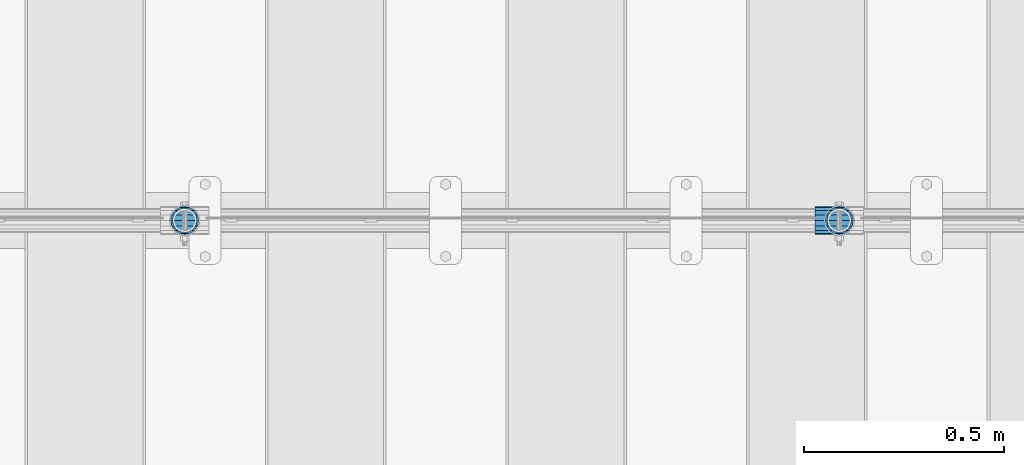
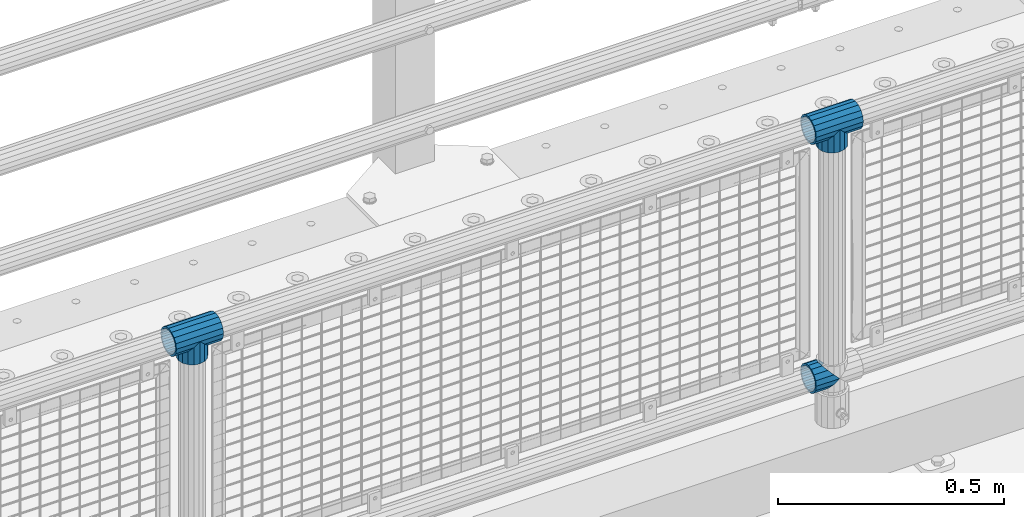
# One storey, part 180 of 270: 5 beams.
"""IFC2X3 building model written with IfcOpenShell, lengths in millimetres."""

from ifc_helpers import new_model, si_unit, frame, origin_with_axes, place, context, subcontext, project, spatial, faceted_brep, material, type_object, element, save


model = new_model("IFC2X3")

# Units and contexts
model_context = context("Model", 3, precision=1e-05, world=origin_with_axes())
body_context = subcontext(model_context, "Body", "Model", "MODEL_VIEW")
ifc_project = project(units=[si_unit("LENGTHUNIT", "METRE", prefix="MILLI"), si_unit("AREAUNIT", "SQUARE_METRE"), si_unit("VOLUMEUNIT", "CUBIC_METRE"), si_unit("MASSUNIT", "GRAM", prefix="KILO"), si_unit("TIMEUNIT", "SECOND"), si_unit("PLANEANGLEUNIT", "RADIAN"), si_unit("SOLIDANGLEUNIT", "STERADIAN"), si_unit("THERMODYNAMICTEMPERATUREUNIT", "DEGREE_CELSIUS"), si_unit("LUMINOUSINTENSITYUNIT", "LUMEN")], contexts=[model_context])

# Site, building, storey
site_placement = place(None, origin_with_axes())
site = spatial("IfcSite", under=ifc_project, at=site_placement, CompositionType="ELEMENT")
building_placement = place(site_placement, origin_with_axes())
building = spatial("IfcBuilding", under=site, at=building_placement, Name="Standard", CompositionType="ELEMENT")
storey_placement = place(building_placement, origin_with_axes())
storey = spatial("IfcBuildingStorey", under=building, at=storey_placement, Name="Undefined", CompositionType="ELEMENT", Elevation=0.0)

# Beams
ifc_material = material(Name="Misc_Undefined")
beam_type = type_object("IfcBeamType", PredefinedType="NOTDEFINED")
beam_1_placement = place(storey_placement, frame((16890.85, -16335.5, 298.17), z_axis=(0.0, 1.0, 0.0), x_axis=(1.0, 0.0, 0.0)))
element("IfcBeam", 1, at=beam_1_placement, inside=storey, type_object=beam_type, material=ifc_material, context=body_context, shape_type="Brep", body=[
    faceted_brep([(60.1499999999978, 0.0, -35.1499999999996), (46.698677352364, 13.4513226476329, -32.4743655677721), (46.698677352364, -13.4513226476329, -32.4743655677721), (33.0273231408937, 21.4606908090117, 21.4606908090118), (27.6756344322275, 26.8123795176776, 13.4513226476338), (27.6756344322275, 32.4743655677717, 13.4513226476338), (35.2951966412911, 24.8548033587072, 24.8548033587067), (35.2951966412911, 16.3810424080045, 24.8548033587067), (27.310256188277, 28.0397438117175, 11.6144421722802), (24.9999999999964, 30.35, 0.0), (24.9999999999964, 35.15, 0.0), (27.6756344322275, 26.8123795176775, -13.4513226476338), (27.6756344322275, 32.4743655677717, -13.4513226476338), (27.310256188277, 28.0397438117175, -11.6144421722802), (35.2951966412911, 16.3810424080045, -24.8548033587067), (35.2951966412911, 24.8548033587072, -24.8548033587067), (33.0273231408937, 21.4606908090117, -21.4606908090118), (40.0617968770166, 11.6144421722805, -28.0397438117179), (43.519339601633, 0.0, -30.3500000000004), (40.0617968770166, -11.6144421722805, -28.0397438117179), (35.2951966412911, -16.3810424080045, -24.8548033587067), (35.2951966412911, -24.8548033587072, -24.8548033587067), (33.0273231408937, -21.4606908090117, -21.4606908090118), (27.6756344322275, -26.8123795176776, -13.4513226476338), (27.6756344322275, -32.4743655677717, -13.4513226476338), (27.310256188277, -28.0397438117175, -11.6144421722802), (24.9999999999964, -30.35, 0.0), (24.9999999999964, -35.15, 0.0), (27.310256188277, -28.0397438117175, 11.6144421722802), (27.6756344322275, -26.8123795176775, 13.4513226476338), (27.6756344322275, -32.4743655677717, 13.4513226476338), (33.0273231408937, -21.4606908090117, 21.4606908090118), (35.2951966412911, -16.3810424080078, 24.8548033587067), (35.2951966412911, -24.8548033587072, 24.8548033587067), (60.1499999999978, 0.0, 35.1499999999996), (46.698677352364, -13.4513226476329, 32.4743655677721), (46.698677352364, 13.4513226476329, 32.4743655677721), (40.061796877013, -11.6144421722805, 28.0397438117179), (43.5193396016293, 0.0, 30.3500000000004), (40.061796877013, 11.6144421722805, 28.0397438117179), (0.0, -32.4743655677721, -13.4513226476338), (0.0, -24.8548033587067, -24.8548033587067), (0.0, -13.4513226476338, -32.4743655677703), (0.0, 0.0, -35.1499999999996), (0.0, 13.4513226476338, -32.4743655677703), (0.0, 24.8548033587067, -24.8548033587067), (0.0, 32.4743655677721, -13.4513226476338), (0.0, 35.1499999999996, 0.0), (0.0, 32.4743655677721, 13.4513226476338), (0.0, 24.8548033587067, 24.8548033587067), (0.0, 13.4513226476338, 32.4743655677703), (0.0, 0.0, 35.1499999999996), (0.0, -32.4743655677721, 13.4513226476338), (0.0, -35.1499999999996, 0.0), (0.0, -24.8548033587067, 24.8548033587067), (0.0, -13.4513226476338, 32.4743655677703), (0.0, -28.0397438117179, -11.614442172282), (0.0, -21.4606908090118, -21.46069080901), (0.0, -11.6144421722802, -28.0397438117179), (0.0, 0.0, -30.3499999999985), (0.0, 11.6144421722802, -28.0397438117179), (0.0, 21.4606908090118, -21.46069080901), (0.0, 28.0397438117179, -11.614442172282), (0.0, 30.3500000000004, 0.0), (0.0, 28.0397438117179, 11.614442172282), (0.0, 21.4606908090118, 21.46069080901), (0.0, 11.6144421722802, 28.0397438117179), (0.0, 0.0, 30.3499999999985), (0.0, -11.6144421722802, 28.0397438117179), (0.0, -21.4606908090118, 21.46069080901), (0.0, -28.0397438117179, 11.614442172282), (0.0, -30.3500000000004, 0.0)], [[[0, 1, 2]], [[3, 4, 5, 6, 7]], [[8, 9, 10, 5, 4]], [[11, 12, 10, 9, 13]], [[14, 15, 12, 11, 16]], [[2, 1, 15, 14, 17, 18, 19, 20, 21]], [[21, 20, 22, 23, 24]], [[24, 23, 25, 26, 27]], [[27, 26, 28, 29, 30]], [[30, 29, 31, 32, 33]], [[34, 35, 36]], [[33, 32, 37, 38, 39, 7, 6, 36, 35]], [[40, 41, 21, 24]], [[41, 42, 2, 21]], [[42, 43, 0, 2]], [[43, 44, 1, 0]], [[44, 45, 15, 1]], [[45, 46, 12, 15]], [[46, 47, 10, 12]], [[47, 48, 5, 10]], [[48, 49, 6, 5]], [[49, 50, 36, 6]], [[50, 51, 34, 36]], [[52, 53, 27, 30]], [[54, 52, 30, 33]], [[55, 54, 33, 35]], [[51, 55, 35, 34]], [[53, 40, 24, 27]], [[52, 54, 55, 51, 50, 49, 48, 47, 46, 45, 44, 43, 42, 41, 40, 53], [56, 57, 58, 59, 60, 61, 62, 63, 64, 65, 66, 67, 68, 69, 70, 71]], [[68, 67, 38, 37]], [[31, 69, 68, 37, 32]], [[28, 70, 69, 31, 29]], [[71, 70, 28, 26]], [[56, 71, 26, 25]], [[57, 56, 25, 23, 22]], [[58, 57, 22, 20, 19]], [[59, 58, 19, 18]], [[60, 59, 18, 17]], [[16, 61, 60, 17, 14]], [[13, 62, 61, 16, 11]], [[63, 62, 13, 9]], [[64, 63, 9, 8]], [[65, 64, 8, 4, 3]], [[66, 65, 3, 7, 39]], [[67, 66, 39, 38]]]),
])
beam_2_placement = place(storey_placement, frame((15318.0, -16335.5, 969.849999999999), z_axis=(0.0, 1.0, 0.0), x_axis=(0.0, 0.0, -1.0)))
element("IfcBeam", 2, at=beam_2_placement, inside=storey, type_object=beam_type, material=ifc_material, context=body_context, shape_type="Brep", body=[
    faceted_brep([(13.4513226476338, 13.4513226476329, 32.4743655677721), (13.4513226476338, -13.4513226476329, 32.4743655677721), (0.0, 0.0, 35.1499999999996), (27.1226768591041, -21.4606908090117, -21.4606908090118), (24.8548033587067, -16.3810424080045, -24.8548033587067), (24.8548033587067, -24.8548033587072, -24.8548033587067), (32.4743655677703, -32.4743655677717, -13.4513226476338), (32.4743655677703, -26.8123795176776, -13.4513226476338), (0.0, 0.0, -35.1499999999996), (13.4513226476338, -13.4513226476329, -32.4743655677721), (13.4513226476338, 13.4513226476329, -32.4743655677721), (20.0882031229849, -11.6144421722805, -28.0397438117179), (16.6306603983721, 0.0, -30.3500000000004), (20.0882031229849, 11.6144421722805, -28.0397438117179), (24.8548033587067, 16.3810424080045, -24.8548033587067), (24.8548033587067, 24.8548033587072, -24.8548033587067), (27.1226768591041, 21.4606908090117, -21.4606908090118), (32.4743655677703, 26.8123795176775, -13.4513226476338), (32.4743655677703, 32.4743655677717, -13.4513226476338), (32.8397438117172, 28.0397438117175, -11.6144421722802), (35.1500000000015, 30.35, 0.0), (35.1500000000015, 35.1500000000003, 0.0), (32.8397438117208, 28.0397438117175, 11.6144421722802), (32.4743655677703, 26.8123795176776, 13.4513226476338), (32.4743655677703, 32.4743655677717, 13.4513226476338), (27.1226768591041, 21.4606908090117, 21.4606908090118), (24.8548033587067, 16.3810424080045, 24.8548033587067), (24.8548033587067, 24.8548033587072, 24.8548033587067), (20.0882031229812, 11.6144421722805, 28.0397438117179), (16.6306603983612, 0.0, 30.3500000000004), (20.0882031229812, -11.6144421722805, 28.0397438117179), (24.8548033587067, -16.3810424080045, 24.8548033587067), (24.8548033587067, -24.8548033587072, 24.8548033587067), (32.4743655677703, -26.8123795176775, 13.4513226476338), (32.4743655677703, -32.4743655677717, 13.4513226476338), (27.1226768591041, -21.4606908090117, 21.4606908090118), (35.1500000000015, -30.35, 0.0), (35.1500000000015, -35.15, 0.0), (32.8397438117208, -28.0397438117175, 11.6144421722802), (32.8397438117172, -28.0397438117175, -11.6144421722802), (60.1500000000015, -24.8548033587072, -24.8548033587067), (60.1500000000015, -32.4743655677717, -13.4513226476338), (60.1500000000015, -13.4513226476329, -32.4743655677721), (60.1499999999978, 0.0, -35.1499999999996), (60.1500000000015, 13.4513226476329, -32.4743655677721), (60.1500000000015, 24.8548033587072, -24.8548033587067), (60.1500000000015, 32.4743655677717, -13.4513226476338), (60.1500000000015, 35.15, 0.0), (60.1500000000015, 32.4743655677717, 13.4513226476338), (60.1500000000015, 24.8548033587072, 24.8548033587067), (60.1500000000015, 13.4513226476329, 32.4743655677721), (60.1499999999978, 0.0, 35.1499999999996), (60.1500000000015, -13.4513226476329, 32.4743655677721), (60.1500000000015, -24.8548033587072, 24.8548033587067), (60.1500000000015, -32.4743655677717, 13.4513226476338), (60.1500000000015, -35.15, 0.0), (60.1500000000015, -21.4606908090117, 21.4606908090118), (60.1500000000015, -11.6144421722805, 28.0397438117179), (60.1500000000015, 0.0, 30.3500000000004), (60.1500000000015, 11.6144421722805, 28.0397438117179), (60.1500000000015, 21.4606908090117, 21.4606908090118), (60.1500000000015, 28.0397438117175, 11.6144421722802), (60.1500000000015, 30.35, 0.0), (60.1500000000015, 28.0397438117175, -11.6144421722802), (60.1500000000015, 21.4606908090117, -21.4606908090118), (60.1500000000015, 11.6144421722805, -28.0397438117179), (60.1500000000015, 0.0, -30.3500000000004), (60.1500000000015, -11.6144421722805, -28.0397438117179), (60.1500000000015, -21.4606908090117, -21.4606908090118), (60.1500000000015, -28.0397438117175, -11.6144421722802), (60.1500000000015, -30.35, 0.0), (60.1500000000015, -28.0397438117175, 11.6144421722802)], [[[0, 1, 2]], [[3, 4, 5, 6, 7]], [[8, 9, 10]], [[10, 9, 5, 4, 11, 12, 13, 14, 15]], [[15, 14, 16, 17, 18]], [[18, 17, 19, 20, 21]], [[21, 20, 22, 23, 24]], [[24, 23, 25, 26, 27]], [[27, 26, 28, 29, 30, 31, 32, 1, 0]], [[33, 34, 32, 31, 35]], [[36, 37, 34, 33, 38]], [[39, 7, 6, 37, 36]], [[40, 41, 6, 5]], [[42, 40, 5, 9]], [[43, 42, 9, 8]], [[44, 43, 8, 10]], [[45, 44, 10, 15]], [[46, 45, 15, 18]], [[47, 46, 18, 21]], [[48, 47, 21, 24]], [[49, 48, 24, 27]], [[50, 49, 27, 0]], [[51, 50, 0, 2]], [[52, 51, 2, 1]], [[53, 52, 1, 32]], [[54, 53, 32, 34]], [[55, 54, 34, 37]], [[41, 55, 37, 6]], [[40, 42, 43, 44, 45, 46, 47, 48, 49, 50, 51, 52, 53, 54, 55, 41], [56, 57, 58, 59, 60, 61, 62, 63, 64, 65, 66, 67, 68, 69, 70, 71]], [[71, 70, 36, 38]], [[35, 56, 71, 38, 33]], [[30, 57, 56, 35, 31]], [[58, 57, 30, 29]], [[59, 58, 29, 28]], [[60, 59, 28, 26, 25]], [[61, 60, 25, 23, 22]], [[62, 61, 22, 20]], [[63, 62, 20, 19]], [[16, 64, 63, 19, 17]], [[13, 65, 64, 16, 14]], [[66, 65, 13, 12]], [[67, 66, 12, 11]], [[68, 67, 11, 4, 3]], [[69, 68, 3, 7, 39]], [[70, 69, 39, 36]]]),
])
beam_3_placement = place(storey_placement, frame((15257.85, -16335.5, 969.849999999999), z_axis=(0.0, 0.0, 1.0), x_axis=(1.0, 0.0, 0.0)))
element("IfcBeam", 3, at=beam_3_placement, inside=storey, type_object=beam_type, material=ifc_material, context=body_context, shape_type="Brep", body=[
    faceted_brep([(88.1897438117176, -11.6144421722802, -28.0397438117176), (88.1897438117176, -11.6144421722802, -32.839743811718), (86.9623795176758, -13.4513226476338, -32.4743655677718), (81.6106908090119, -21.4606908090118, -27.1226768591079), (81.6106908090119, -21.4606908090118, -21.4606908090117), (76.5310424080044, -24.8548033587067, -24.8548033587072), (71.7644421722807, -28.0397438117179, -20.0882031229829), (71.7644421722807, -28.0397438117179, -11.6144421722805), (60.1500000000001, -30.3500000000004, -16.6306603983638), (60.1500000000015, -30.35, 0.0), (48.5355578277195, -28.0397438117179, -20.0882031229829), (48.5355578277195, -28.0397438117179, -11.6144421722805), (43.7689575919958, -24.8548033587067, -24.8548033587072), (38.6893091909883, -21.4606908090118, -27.1226768591079), (38.6893091909883, -21.4606908090118, -21.4606908090117), (33.3376204823235, -13.4513226476338, -32.4743655677718), (32.1102561882826, -11.6144421722802, -32.839743811718), (32.1102561882826, -11.6144421722802, -28.0397438117176), (29.8000000000002, 0.0, -35.15), (29.8000000000002, 0.0, -30.35), (32.1102561882826, 11.6144421722802, -32.839743811718), (32.1102561882826, 11.6144421722802, -28.0397438117176), (33.3376204823244, 13.4513226476338, -32.4743655677718), (38.6893091909883, 21.4606908090118, -27.1226768591056), (38.6893091909883, 21.4606908090118, -21.4606908090117), (43.7689575919958, 24.8548033587067, -24.8548033587072), (48.5355578277195, 28.0397438117179, -20.0882031229829), (48.5355578277195, 28.0397438117179, -11.6144421722805), (60.1500000000001, 30.3500000000004, -16.6306603983638), (60.1500000000015, 30.35, 0.0), (71.7644421722807, 28.0397438117179, -20.0882031229829), (71.7644421722807, 28.0397438117179, -11.6144421722805), (76.5310424080044, 24.8548033587067, -24.8548033587072), (81.6106908090119, 21.4606908090118, -27.1226768591056), (81.6106908090119, 21.4606908090118, -21.4606908090117), (86.9623795176776, 13.4513226476338, -32.4743655677718), (88.1897438117176, 11.6144421722802, -32.839743811718), (88.1897438117176, 11.6144421722802, -28.0397438117176), (90.5, 0.0, -35.15), (90.5, 0.0, -30.35), (0.0, -21.4606908090118, -21.46069080901), (0.0, -28.0397438117179, -11.614442172282), (0.0, -11.6144421722802, -28.0397438117179), (0.0, 0.0, -30.3499999999985), (0.0, 11.6144421722802, -28.0397438117179), (0.0, 21.4606908090118, -21.46069080901), (0.0, 28.0397438117179, -11.614442172282), (0.0, 30.3500000000004, 0.0), (0.0, 32.4743655677721, -13.4513226476338), (0.0, 35.1499999999996, 0.0), (120.3, 35.1499999999996, 0.0), (120.3, 32.4743655677721, -13.4513226476329), (0.0, 32.4743655677721, 13.4513226476338), (120.3, 32.4743655677721, 13.4513226476329), (0.0, 24.8548033587067, 24.8548033587067), (120.3, 24.8548033587067, 24.8548033587072), (0.0, 13.4513226476338, 32.4743655677703), (120.3, 13.4513226476338, 32.4743655677718), (0.0, 0.0, 35.1499999999996), (120.3, 0.0, 35.15), (0.0, -13.4513226476338, 32.4743655677703), (120.3, -13.4513226476338, 32.4743655677718), (0.0, -24.8548033587067, 24.8548033587067), (120.3, -24.8548033587067, 24.8548033587072), (0.0, -32.4743655677721, 13.4513226476338), (120.3, -32.4743655677721, 13.4513226476329), (0.0, -35.1499999999996, 0.0), (120.3, -35.1499999999996, 0.0), (0.0, -32.4743655677721, -13.4513226476338), (120.3, -32.4743655677721, -13.4513226476329), (0.0, 24.8548033587067, -24.8548033587067), (0.0, 13.4513226476338, -32.4743655677703), (0.0, 0.0, -35.1499999999996), (0.0, -13.4513226476338, -32.4743655677703), (0.0, -24.8548033587067, -24.8548033587067), (0.0, 28.0397438117179, 11.614442172282), (0.0, 21.4606908090118, 21.46069080901), (0.0, 11.6144421722802, 28.0397438117179), (0.0, 0.0, 30.3499999999985), (0.0, -11.6144421722802, 28.0397438117179), (0.0, -21.4606908090118, 21.46069080901), (0.0, -28.0397438117179, 11.614442172282), (0.0, -30.3500000000004, 0.0), (120.3, -30.3500000000004, 0.0), (120.3, -28.0397438117179, -11.6144421722805), (120.3, -21.4606908090118, -21.4606908090117), (120.3, -11.6144421722802, -28.0397438117176), (120.3, 0.0, -30.35), (120.3, 21.4606908090118, -21.4606908090117), (120.3, 28.0397438117179, -11.6144421722805), (120.3, 11.6144421722802, -28.0397438117176), (120.3, 30.3500000000004, 0.0), (120.3, 28.0397438117179, 11.6144421722805), (120.3, 21.4606908090118, 21.4606908090117), (120.3, 11.6144421722802, 28.0397438117176), (120.3, 0.0, 30.35), (120.3, -11.6144421722802, 28.0397438117176), (120.3, -21.4606908090118, 21.4606908090117), (120.3, -28.0397438117179, 11.6144421722805), (120.3, -24.8548033587067, -24.8548033587072), (120.3, -13.4513226476338, -32.4743655677718), (120.3, 0.0, -35.15), (120.3, 13.4513226476338, -32.4743655677718), (120.3, 24.8548033587067, -24.8548033587072)], [[[0, 1, 2, 3, 4]], [[4, 3, 5, 6, 7]], [[7, 6, 8, 9]], [[9, 8, 10, 11]], [[11, 10, 12, 13, 14]], [[14, 13, 15, 16, 17]], [[17, 16, 18, 19]], [[19, 18, 20, 21]], [[21, 20, 22, 23, 24]], [[24, 23, 25, 26, 27]], [[27, 26, 28, 29]], [[29, 28, 30, 31]], [[31, 30, 32, 33, 34]], [[34, 33, 35, 36, 37]], [[37, 36, 38, 39]], [[39, 38, 1, 0]], [[40, 41, 11, 14]], [[42, 40, 14, 17]], [[43, 42, 17, 19]], [[44, 43, 19, 21]], [[45, 44, 21, 24]], [[46, 45, 24, 27]], [[47, 46, 27, 29]], [[48, 49, 50, 51]], [[49, 52, 53, 50]], [[52, 54, 55, 53]], [[54, 56, 57, 55]], [[56, 58, 59, 57]], [[58, 60, 61, 59]], [[60, 62, 63, 61]], [[62, 64, 65, 63]], [[64, 66, 67, 65]], [[66, 68, 69, 67]], [[64, 62, 60, 58, 56, 54, 52, 49, 48, 70, 71, 72, 73, 74, 68, 66], [41, 40, 42, 43, 44, 45, 46, 47, 75, 76, 77, 78, 79, 80, 81, 82]], [[41, 82, 9, 11]], [[83, 84, 7, 9]], [[84, 85, 4, 7]], [[85, 86, 0, 4]], [[86, 87, 39, 0]], [[88, 89, 31, 34]], [[90, 88, 34, 37]], [[87, 90, 37, 39]], [[89, 91, 29, 31]], [[75, 47, 29, 91, 92]], [[76, 75, 92, 93]], [[77, 76, 93, 94]], [[78, 77, 94, 95]], [[79, 78, 95, 96]], [[80, 79, 96, 97]], [[81, 80, 97, 98]], [[9, 82, 81, 98, 83]], [[99, 100, 101, 102, 103, 51, 50, 53, 55, 57, 59, 61, 63, 65, 67, 69], [97, 96, 95, 94, 93, 92, 91, 89, 88, 90, 87, 86, 85, 84, 83, 98]], [[35, 102, 101, 38, 36]], [[32, 103, 102, 35, 33]], [[28, 26, 25, 70, 48, 51, 103, 32, 30]], [[22, 71, 70, 25, 23]], [[18, 72, 71, 22, 20]], [[73, 72, 18, 16, 15]], [[74, 73, 15, 13, 12]], [[99, 69, 68, 74, 12, 10, 8, 6, 5]], [[100, 99, 5, 3, 2]], [[101, 100, 2, 1, 38]]]),
])
beam_4_placement = place(storey_placement, frame((16951.0, -16335.5, 969.849999999999), z_axis=(0.0, 1.0, 0.0), x_axis=(0.0, 0.0, -1.0)))
element("IfcBeam", 4, at=beam_4_placement, inside=storey, type_object=beam_type, material=ifc_material, context=body_context, shape_type="Brep", body=[
    faceted_brep([(13.4513226476338, 13.4513226476329, 32.4743655677721), (13.4513226476338, -13.4513226476329, 32.4743655677721), (0.0, 0.0, 35.1499999999996), (27.1226768591041, -21.4606908090117, -21.4606908090118), (24.8548033587067, -16.3810424080045, -24.8548033587067), (24.8548033587067, -24.8548033587072, -24.8548033587067), (32.4743655677703, -32.4743655677717, -13.4513226476338), (32.4743655677703, -26.8123795176776, -13.4513226476338), (0.0, 0.0, -35.1499999999996), (13.4513226476338, -13.4513226476329, -32.4743655677721), (13.4513226476338, 13.4513226476329, -32.4743655677721), (20.0882031229849, -11.6144421722805, -28.0397438117179), (16.6306603983721, 0.0, -30.3500000000004), (20.0882031229849, 11.6144421722805, -28.0397438117179), (24.8548033587067, 16.3810424080045, -24.8548033587067), (24.8548033587067, 24.8548033587072, -24.8548033587067), (27.1226768591041, 21.4606908090117, -21.4606908090118), (32.4743655677703, 26.8123795176775, -13.4513226476338), (32.4743655677703, 32.4743655677717, -13.4513226476338), (32.8397438117172, 28.0397438117175, -11.6144421722802), (35.1500000000015, 30.35, 0.0), (35.1500000000015, 35.1500000000003, 0.0), (32.8397438117208, 28.0397438117175, 11.6144421722802), (32.4743655677703, 26.8123795176776, 13.4513226476338), (32.4743655677703, 32.4743655677717, 13.4513226476338), (27.1226768591041, 21.4606908090117, 21.4606908090118), (24.8548033587067, 16.3810424080045, 24.8548033587067), (24.8548033587067, 24.8548033587072, 24.8548033587067), (20.0882031229812, 11.6144421722805, 28.0397438117179), (16.6306603983612, 0.0, 30.3500000000004), (20.0882031229812, -11.6144421722805, 28.0397438117179), (24.8548033587067, -16.3810424080045, 24.8548033587067), (24.8548033587067, -24.8548033587072, 24.8548033587067), (32.4743655677703, -26.8123795176775, 13.4513226476338), (32.4743655677703, -32.4743655677717, 13.4513226476338), (27.1226768591041, -21.4606908090117, 21.4606908090118), (35.1500000000015, -30.35, 0.0), (35.1500000000015, -35.15, 0.0), (32.8397438117208, -28.0397438117175, 11.6144421722802), (32.8397438117172, -28.0397438117175, -11.6144421722802), (60.1500000000015, -24.8548033587072, -24.8548033587067), (60.1500000000015, -32.4743655677717, -13.4513226476338), (60.1500000000015, -13.4513226476329, -32.4743655677721), (60.1499999999978, 0.0, -35.1499999999996), (60.1500000000015, 13.4513226476329, -32.4743655677721), (60.1500000000015, 24.8548033587072, -24.8548033587067), (60.1500000000015, 32.4743655677717, -13.4513226476338), (60.1500000000015, 35.15, 0.0), (60.1500000000015, 32.4743655677717, 13.4513226476338), (60.1500000000015, 24.8548033587072, 24.8548033587067), (60.1500000000015, 13.4513226476329, 32.4743655677721), (60.1499999999978, 0.0, 35.1499999999996), (60.1500000000015, -13.4513226476329, 32.4743655677721), (60.1500000000015, -24.8548033587072, 24.8548033587067), (60.1500000000015, -32.4743655677717, 13.4513226476338), (60.1500000000015, -35.15, 0.0), (60.1500000000015, -21.4606908090117, 21.4606908090118), (60.1500000000015, -11.6144421722805, 28.0397438117179), (60.1500000000015, 0.0, 30.3500000000004), (60.1500000000015, 11.6144421722805, 28.0397438117179), (60.1500000000015, 21.4606908090117, 21.4606908090118), (60.1500000000015, 28.0397438117175, 11.6144421722802), (60.1500000000015, 30.35, 0.0), (60.1500000000015, 28.0397438117175, -11.6144421722802), (60.1500000000015, 21.4606908090117, -21.4606908090118), (60.1500000000015, 11.6144421722805, -28.0397438117179), (60.1500000000015, 0.0, -30.3500000000004), (60.1500000000015, -11.6144421722805, -28.0397438117179), (60.1500000000015, -21.4606908090117, -21.4606908090118), (60.1500000000015, -28.0397438117175, -11.6144421722802), (60.1500000000015, -30.35, 0.0), (60.1500000000015, -28.0397438117175, 11.6144421722802)], [[[0, 1, 2]], [[3, 4, 5, 6, 7]], [[8, 9, 10]], [[10, 9, 5, 4, 11, 12, 13, 14, 15]], [[15, 14, 16, 17, 18]], [[18, 17, 19, 20, 21]], [[21, 20, 22, 23, 24]], [[24, 23, 25, 26, 27]], [[27, 26, 28, 29, 30, 31, 32, 1, 0]], [[33, 34, 32, 31, 35]], [[36, 37, 34, 33, 38]], [[39, 7, 6, 37, 36]], [[40, 41, 6, 5]], [[42, 40, 5, 9]], [[43, 42, 9, 8]], [[44, 43, 8, 10]], [[45, 44, 10, 15]], [[46, 45, 15, 18]], [[47, 46, 18, 21]], [[48, 47, 21, 24]], [[49, 48, 24, 27]], [[50, 49, 27, 0]], [[51, 50, 0, 2]], [[52, 51, 2, 1]], [[53, 52, 1, 32]], [[54, 53, 32, 34]], [[55, 54, 34, 37]], [[41, 55, 37, 6]], [[40, 42, 43, 44, 45, 46, 47, 48, 49, 50, 51, 52, 53, 54, 55, 41], [56, 57, 58, 59, 60, 61, 62, 63, 64, 65, 66, 67, 68, 69, 70, 71]], [[71, 70, 36, 38]], [[35, 56, 71, 38, 33]], [[30, 57, 56, 35, 31]], [[58, 57, 30, 29]], [[59, 58, 29, 28]], [[60, 59, 28, 26, 25]], [[61, 60, 25, 23, 22]], [[62, 61, 22, 20]], [[63, 62, 20, 19]], [[16, 64, 63, 19, 17]], [[13, 65, 64, 16, 14]], [[66, 65, 13, 12]], [[67, 66, 12, 11]], [[68, 67, 11, 4, 3]], [[69, 68, 3, 7, 39]], [[70, 69, 39, 36]]]),
])
beam_5_placement = place(storey_placement, frame((16890.85, -16335.5, 969.849999999999), z_axis=(0.0, 0.0, 1.0), x_axis=(1.0, 0.0, 0.0)))
element("IfcBeam", 5, at=beam_5_placement, inside=storey, type_object=beam_type, material=ifc_material, context=body_context, shape_type="Brep", body=[
    faceted_brep([(88.1897438117176, -11.6144421722802, -28.0397438117176), (88.1897438117176, -11.6144421722802, -32.839743811718), (86.9623795176758, -13.4513226476338, -32.4743655677718), (81.6106908090119, -21.4606908090118, -27.1226768591079), (81.6106908090119, -21.4606908090118, -21.4606908090117), (76.5310424080044, -24.8548033587067, -24.8548033587072), (71.7644421722807, -28.0397438117179, -20.0882031229829), (71.7644421722807, -28.0397438117179, -11.6144421722805), (60.1500000000001, -30.3500000000004, -16.6306603983638), (60.1500000000015, -30.35, 0.0), (48.5355578277195, -28.0397438117179, -20.0882031229829), (48.5355578277195, -28.0397438117179, -11.6144421722805), (43.7689575919958, -24.8548033587067, -24.8548033587072), (38.6893091909883, -21.4606908090118, -27.1226768591079), (38.6893091909883, -21.4606908090118, -21.4606908090117), (33.3376204823235, -13.4513226476338, -32.4743655677718), (32.1102561882826, -11.6144421722802, -32.839743811718), (32.1102561882826, -11.6144421722802, -28.0397438117176), (29.8000000000002, 0.0, -35.15), (29.8000000000002, 0.0, -30.35), (32.1102561882826, 11.6144421722802, -32.839743811718), (32.1102561882826, 11.6144421722802, -28.0397438117176), (33.3376204823244, 13.4513226476338, -32.4743655677718), (38.6893091909883, 21.4606908090118, -27.1226768591056), (38.6893091909883, 21.4606908090118, -21.4606908090117), (43.7689575919958, 24.8548033587067, -24.8548033587072), (48.5355578277195, 28.0397438117179, -20.0882031229829), (48.5355578277195, 28.0397438117179, -11.6144421722805), (60.1500000000001, 30.3500000000004, -16.6306603983638), (60.1500000000015, 30.35, 0.0), (71.7644421722807, 28.0397438117179, -20.0882031229829), (71.7644421722807, 28.0397438117179, -11.6144421722805), (76.5310424080044, 24.8548033587067, -24.8548033587072), (81.6106908090119, 21.4606908090118, -27.1226768591056), (81.6106908090119, 21.4606908090118, -21.4606908090117), (86.9623795176776, 13.4513226476338, -32.4743655677718), (88.1897438117176, 11.6144421722802, -32.839743811718), (88.1897438117176, 11.6144421722802, -28.0397438117176), (90.5, 0.0, -35.15), (90.5, 0.0, -30.35), (0.0, -21.4606908090118, -21.46069080901), (0.0, -28.0397438117179, -11.614442172282), (0.0, -11.6144421722802, -28.0397438117179), (0.0, 0.0, -30.3499999999985), (0.0, 11.6144421722802, -28.0397438117179), (0.0, 21.4606908090118, -21.46069080901), (0.0, 28.0397438117179, -11.614442172282), (0.0, 30.3500000000004, 0.0), (0.0, 32.4743655677721, -13.4513226476338), (0.0, 35.1499999999996, 0.0), (120.3, 35.1499999999996, 0.0), (120.3, 32.4743655677721, -13.4513226476329), (0.0, 32.4743655677721, 13.4513226476338), (120.3, 32.4743655677721, 13.4513226476329), (0.0, 24.8548033587067, 24.8548033587067), (120.3, 24.8548033587067, 24.8548033587072), (0.0, 13.4513226476338, 32.4743655677703), (120.3, 13.4513226476338, 32.4743655677718), (0.0, 0.0, 35.1499999999996), (120.3, 0.0, 35.15), (0.0, -13.4513226476338, 32.4743655677703), (120.3, -13.4513226476338, 32.4743655677718), (0.0, -24.8548033587067, 24.8548033587067), (120.3, -24.8548033587067, 24.8548033587072), (0.0, -32.4743655677721, 13.4513226476338), (120.3, -32.4743655677721, 13.4513226476329), (0.0, -35.1499999999996, 0.0), (120.3, -35.1499999999996, 0.0), (0.0, -32.4743655677721, -13.4513226476338), (120.3, -32.4743655677721, -13.4513226476329), (0.0, 24.8548033587067, -24.8548033587067), (0.0, 13.4513226476338, -32.4743655677703), (0.0, 0.0, -35.1499999999996), (0.0, -13.4513226476338, -32.4743655677703), (0.0, -24.8548033587067, -24.8548033587067), (0.0, 28.0397438117179, 11.614442172282), (0.0, 21.4606908090118, 21.46069080901), (0.0, 11.6144421722802, 28.0397438117179), (0.0, 0.0, 30.3499999999985), (0.0, -11.6144421722802, 28.0397438117179), (0.0, -21.4606908090118, 21.46069080901), (0.0, -28.0397438117179, 11.614442172282), (0.0, -30.3500000000004, 0.0), (120.3, -30.3500000000004, 0.0), (120.3, -28.0397438117179, -11.6144421722805), (120.3, -21.4606908090118, -21.4606908090117), (120.3, -11.6144421722802, -28.0397438117176), (120.3, 0.0, -30.35), (120.3, 21.4606908090118, -21.4606908090117), (120.3, 28.0397438117179, -11.6144421722805), (120.3, 11.6144421722802, -28.0397438117176), (120.3, 30.3500000000004, 0.0), (120.3, 28.0397438117179, 11.6144421722805), (120.3, 21.4606908090118, 21.4606908090117), (120.3, 11.6144421722802, 28.0397438117176), (120.3, 0.0, 30.35), (120.3, -11.6144421722802, 28.0397438117176), (120.3, -21.4606908090118, 21.4606908090117), (120.3, -28.0397438117179, 11.6144421722805), (120.3, -24.8548033587067, -24.8548033587072), (120.3, -13.4513226476338, -32.4743655677718), (120.3, 0.0, -35.15), (120.3, 13.4513226476338, -32.4743655677718), (120.3, 24.8548033587067, -24.8548033587072)], [[[0, 1, 2, 3, 4]], [[4, 3, 5, 6, 7]], [[7, 6, 8, 9]], [[9, 8, 10, 11]], [[11, 10, 12, 13, 14]], [[14, 13, 15, 16, 17]], [[17, 16, 18, 19]], [[19, 18, 20, 21]], [[21, 20, 22, 23, 24]], [[24, 23, 25, 26, 27]], [[27, 26, 28, 29]], [[29, 28, 30, 31]], [[31, 30, 32, 33, 34]], [[34, 33, 35, 36, 37]], [[37, 36, 38, 39]], [[39, 38, 1, 0]], [[40, 41, 11, 14]], [[42, 40, 14, 17]], [[43, 42, 17, 19]], [[44, 43, 19, 21]], [[45, 44, 21, 24]], [[46, 45, 24, 27]], [[47, 46, 27, 29]], [[48, 49, 50, 51]], [[49, 52, 53, 50]], [[52, 54, 55, 53]], [[54, 56, 57, 55]], [[56, 58, 59, 57]], [[58, 60, 61, 59]], [[60, 62, 63, 61]], [[62, 64, 65, 63]], [[64, 66, 67, 65]], [[66, 68, 69, 67]], [[64, 62, 60, 58, 56, 54, 52, 49, 48, 70, 71, 72, 73, 74, 68, 66], [41, 40, 42, 43, 44, 45, 46, 47, 75, 76, 77, 78, 79, 80, 81, 82]], [[41, 82, 9, 11]], [[83, 84, 7, 9]], [[84, 85, 4, 7]], [[85, 86, 0, 4]], [[86, 87, 39, 0]], [[88, 89, 31, 34]], [[90, 88, 34, 37]], [[87, 90, 37, 39]], [[89, 91, 29, 31]], [[75, 47, 29, 91, 92]], [[76, 75, 92, 93]], [[77, 76, 93, 94]], [[78, 77, 94, 95]], [[79, 78, 95, 96]], [[80, 79, 96, 97]], [[81, 80, 97, 98]], [[9, 82, 81, 98, 83]], [[99, 100, 101, 102, 103, 51, 50, 53, 55, 57, 59, 61, 63, 65, 67, 69], [97, 96, 95, 94, 93, 92, 91, 89, 88, 90, 87, 86, 85, 84, 83, 98]], [[35, 102, 101, 38, 36]], [[32, 103, 102, 35, 33]], [[28, 26, 25, 70, 48, 51, 103, 32, 30]], [[22, 71, 70, 25, 23]], [[18, 72, 71, 22, 20]], [[73, 72, 18, 16, 15]], [[74, 73, 15, 13, 12]], [[99, 69, 68, 74, 12, 10, 8, 6, 5]], [[100, 99, 5, 3, 2]], [[101, 100, 2, 1, 38]]]),
])

save(model, "model.ifc")
